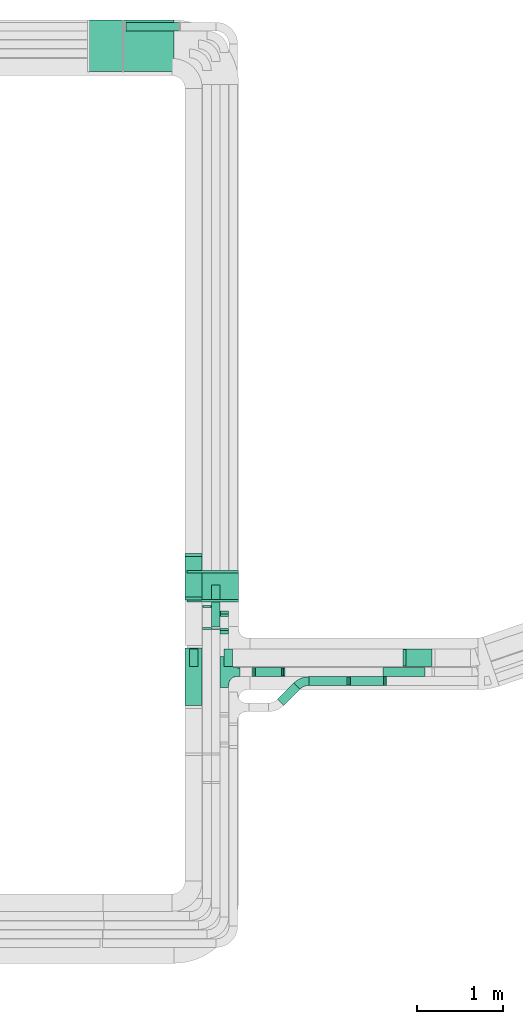
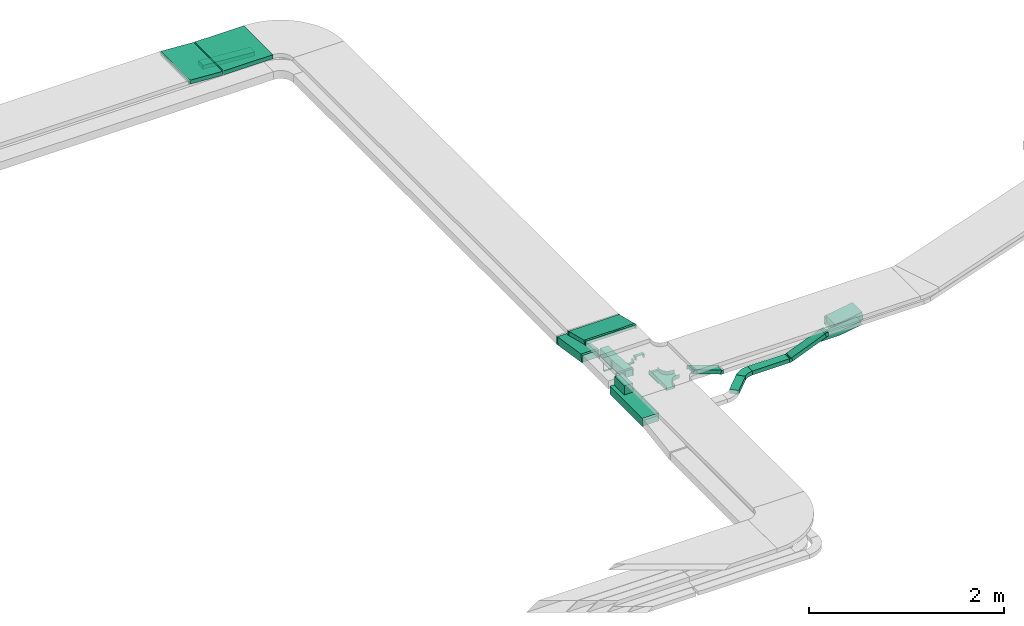
# One storey, part 23 of 28: 18 flow fittings, 13 flow segments.
"""IFC2X3 building model written with IfcOpenShell, lengths in millimetres."""

import ifcopenshell
import ifcopenshell.guid

model = None  # the IFC model being written
_history = None  # IfcOwnerHistory: only IFC2X3 demands one
_inside = {}  # id of a spatial element -> (the spatial element, [elements in it])
_under = {}  # id of a project, library or spatial element -> (it, [spatial elements below it])
_declared = {}  # id of a project -> (the project, [libraries it declares])
_typed = {}  # id of a type object -> (the type object, [elements of that type])
_made_of = {}  # id of a material, layer set ... -> (it, [elements and type objects made of it])


def new_model(schema):
    """Start an empty IFC model of exactly this schema.

    Asked for "IFC4X3", IfcOpenShell would pick the latest addendum, in which some entities
    have other attributes; the version numbers below select the first issue.
    IFC2X3 requires an IfcOwnerHistory on every rooted entity: one is made here for all.
    """
    global model, _history
    if schema == "IFC4X3":
        model = ifcopenshell.file(schema_version=(4, 3, 0, 0))
    else:
        model = ifcopenshell.file(schema=schema)
    _inside.clear()
    _under.clear()
    _declared.clear()
    _typed.clear()
    _made_of.clear()
    _history = None
    if model.schema == "IFC2X3":
        org = make("IfcOrganization", Name="unknown")
        user = make(
            "IfcPersonAndOrganization",
            ThePerson=make("IfcPerson", FamilyName="unknown"),
            TheOrganization=org,
        )
        app = make(
            "IfcApplication",
            ApplicationDeveloper=org,
            Version="unknown",
            ApplicationFullName="unknown",
            ApplicationIdentifier="unknown",
        )
        _history = make(
            "IfcOwnerHistory",
            OwningUser=user,
            OwningApplication=app,
            ChangeAction="ADDED",
            CreationDate=0,
        )
    return model


def make(cls, **values):
    """One entity of the class cls with the attributes given. An attribute that is None is left unset."""
    return model.create_entity(
        cls, **{name: value for name, value in values.items() if value is not None}
    )


def entity(cls, *values):
    """Any entity or typed value of the class cls, its attributes in the order of the schema. None: left unset."""
    e = model.create_entity(cls)
    for i, value in enumerate(values):
        if value is not None:
            e[i] = value
    return e


def rooted(cls, **values):
    """An entity with a GlobalId (a new one), such as an element, a storey or a relation."""
    return make(cls, GlobalId=ifcopenshell.guid.new(), OwnerHistory=_history, **values)


def si_unit(unit_type, name, prefix=None):
    """IfcSIUnit, for example si_unit("LENGTHUNIT", "METRE", prefix="MILLI")."""
    return make("IfcSIUnit", UnitType=unit_type, Prefix=prefix, Name=name)


def converted_unit(unit_type, name, factor, base, dimensions=None, offset=None):
    """IfcConversionBasedUnit, such as the inch: factor (a typed value) times the base unit."""
    return make(
        "IfcConversionBasedUnit"
        if offset is None
        else "IfcConversionBasedUnitWithOffset",
        ConversionOffset=offset,
        Dimensions=None
        if dimensions is None
        else entity("IfcDimensionalExponents", *dimensions),
        UnitType=unit_type,
        Name=name,
        ConversionFactor=make(
            "IfcMeasureWithUnit", ValueComponent=factor, UnitComponent=base
        ),
    )


def derived_unit(unit_type, elements):
    """IfcDerivedUnit: a product of units, each with its exponent."""
    return make(
        "IfcDerivedUnit",
        Elements=[
            make("IfcDerivedUnitElement", Unit=unit, Exponent=power)
            for unit, power in elements
        ],
        UnitType=unit_type,
    )


def assignment(units):
    """IfcUnitAssignment: the units of a project."""
    return None if units is None else make("IfcUnitAssignment", Units=units)


def point(xyz):
    """IfcCartesianPoint."""
    return None if xyz is None else make("IfcCartesianPoint", Coordinates=xyz)


def direction(xyz):
    """IfcDirection."""
    return None if xyz is None else make("IfcDirection", DirectionRatios=xyz)


def frame(location, z_axis=None, x_axis=None):
    """IfcAxis2Placement3D, a coordinate frame: its origin and axes. An axis left out is left unset."""
    return make(
        "IfcAxis2Placement3D",
        Location=point(location),
        Axis=direction(z_axis),
        RefDirection=direction(x_axis),
    )


def frame_2d(location, x_axis=None):
    """IfcAxis2Placement2D, a coordinate frame in the plane: its origin and x axis."""
    return make(
        "IfcAxis2Placement2D", Location=point(location), RefDirection=direction(x_axis)
    )


def origin():
    """The frame at (0, 0, 0) with its axes left unset."""
    return frame((0.0, 0.0, 0.0))


def origin_2d_with_axis():
    """The frame at (0, 0) in the plane with the x axis (1, 0) written out."""
    return frame_2d((0.0, 0.0), x_axis=(1.0, 0.0))


def place(relative_to, where):
    """IfcLocalPlacement: puts the frame where relative to a parent placement (None: the world)."""
    return make(
        "IfcLocalPlacement", PlacementRelTo=relative_to, RelativePlacement=where
    )


def context(
    kind, dimensions, precision=None, world=None, true_north=None, identifier=None
):
    """IfcGeometricRepresentationContext, for example the 3D "Model" context."""
    return make(
        "IfcGeometricRepresentationContext",
        ContextIdentifier=identifier,
        ContextType=kind,
        CoordinateSpaceDimension=dimensions,
        Precision=precision,
        WorldCoordinateSystem=world,
        TrueNorth=true_north,
    )


def subcontext(parent, identifier, kind, view, scale=None):
    """IfcGeometricRepresentationSubContext, for example "Body" below "Model"."""
    return make(
        "IfcGeometricRepresentationSubContext",
        ContextIdentifier=identifier,
        ContextType=kind,
        ParentContext=parent,
        TargetScale=scale,
        TargetView=view,
    )


def project(units=None, contexts=None):
    """IfcProject with its units and contexts."""
    return rooted(
        "IfcProject",
        Name="project",
        RepresentationContexts=contexts,
        UnitsInContext=assignment(units),
    )


def spatial(cls, under=None, at=None, **own):
    """A site, building, storey or space (cls), placed at a placement, below another one or the project."""
    s = rooted(cls, ObjectPlacement=at, **own)
    if under is not None:
        _under.setdefault(under.id(), (under, []))[1].append(s)
    return s


def polyline(points):
    """IfcPolyline through the points."""
    return make("IfcPolyline", Points=[point(p) for p in points])


def circle_curve(where, radius):
    """IfcCircle in the frame where."""
    return make("IfcCircle", Position=where, Radius=radius)


def parameter(value):
    """IfcParameterValue: where a trimmed curve begins or ends, as a parameter of its basis curve."""
    return model.create_entity("IfcParameterValue", value)


def trimmed(basis, trim1, trim2, sense, master):
    """IfcTrimmedCurve: the piece of a basis curve between two trims."""
    return make(
        "IfcTrimmedCurve",
        BasisCurve=basis,
        Trim1=trim1,
        Trim2=trim2,
        SenseAgreement=sense,
        MasterRepresentation=master,
    )


def segment(curve, same_sense, transition):
    """IfcCompositeCurveSegment."""
    return make(
        "IfcCompositeCurveSegment",
        Transition=transition,
        SameSense=same_sense,
        ParentCurve=curve,
    )


def composite_curve(segments, self_intersect=None):
    """IfcCompositeCurve: segments joined end to end."""
    return make("IfcCompositeCurve", Segments=segments, SelfIntersect=self_intersect)


def profile(cls, at=None, kind="AREA", **sizes):
    """A parametric profile (cls). Its sizes go by their IFC names, for example OverallWidth=200.0."""
    return make(cls, ProfileType=kind, Position=at, **sizes)


def rectangle(**sizes):
    """IfcRectangleProfileDef."""
    return profile("IfcRectangleProfileDef", **sizes)


def outline(outer, holes=None, kind="AREA"):
    """IfcArbitraryClosedProfileDef: a profile drawn as a closed curve; with holes, ...WithVoids."""
    if holes is None:
        return make("IfcArbitraryClosedProfileDef", ProfileType=kind, OuterCurve=outer)
    return make(
        "IfcArbitraryProfileDefWithVoids",
        ProfileType=kind,
        OuterCurve=outer,
        InnerCurves=holes,
    )


def extrude(swept, where, along, depth):
    """IfcExtrudedAreaSolid: the profile swept, set in the frame where, extruded along a direction by depth."""
    return make(
        "IfcExtrudedAreaSolid",
        SweptArea=swept,
        Position=where,
        ExtrudedDirection=direction(along),
        Depth=depth,
    )


def faces_of(points, faces, orient=None, outer=None):
    """IfcFace entities. A face is a list of loops; a loop is a list of indices into points, from 0.

    orient and outer hold one flag for each loop. By default every Orientation is true, the
    first loop of a face is its IfcFaceOuterBound and the others are IfcFaceBound.
    """
    made = []
    for i, loops in enumerate(faces):
        bounds = []
        for j, loop in enumerate(loops):
            is_outer = j == 0 if outer is None else outer[i][j]
            bounds.append(
                make(
                    "IfcFaceOuterBound" if is_outer else "IfcFaceBound",
                    Bound=make("IfcPolyLoop", Polygon=[points[k] for k in loop]),
                    Orientation=True if orient is None else orient[i][j],
                )
            )
        made.append(make("IfcFace", Bounds=bounds))
    return made


def faceted_brep(points, faces, orient=None, outer=None, voids=None):
    """IfcFacetedBrep: a solid bounded by flat faces; with voids (closed shells), ...WithVoids."""
    shared = [point(p) for p in points]
    hull = make("IfcClosedShell", CfsFaces=faces_of(shared, faces, orient, outer))
    if voids is None:
        return make("IfcFacetedBrep", Outer=hull)
    return make(
        "IfcFacetedBrepWithVoids",
        Outer=hull,
        Voids=[
            make(cls, CfsFaces=faces_of(shared, fs, o, b)) for cls, fs, o, b in voids
        ],
    )


def shape(context_of_items, identifier, shape_type, items):
    """IfcShapeRepresentation: the items that make up one representation, for example the "Body"."""
    return make(
        "IfcShapeRepresentation",
        ContextOfItems=context_of_items,
        RepresentationIdentifier=identifier,
        RepresentationType=shape_type,
        Items=items,
    )


def source(mapping_origin, context_of_items, identifier, shape_type, items):
    """IfcRepresentationMap: a shape defined once, which mapped items show again and again."""
    return make(
        "IfcRepresentationMap",
        MappingOrigin=mapping_origin,
        MappedRepresentation=shape(context_of_items, identifier, shape_type, items),
    )


def transform(
    local_origin,
    x_axis=None,
    y_axis=None,
    z_axis=None,
    scale=None,
    scale2=None,
    scale3=None,
    uniform=True,
):
    """IfcCartesianTransformationOperator3D, or its non-uniform kind. x_axis, y_axis, z_axis: its Axis1, 2, 3."""
    if uniform:
        return make(
            "IfcCartesianTransformationOperator3D",
            Axis1=direction(x_axis),
            Axis2=direction(y_axis),
            LocalOrigin=point(local_origin),
            Scale=scale,
            Axis3=direction(z_axis),
        )
    return make(
        "IfcCartesianTransformationOperator3DnonUniform",
        Axis1=direction(x_axis),
        Axis2=direction(y_axis),
        LocalOrigin=point(local_origin),
        Scale=scale,
        Axis3=direction(z_axis),
        Scale2=scale2,
        Scale3=scale3,
    )


def mapped(mapping_source, mapping_target):
    """IfcMappedItem: shows the shape of a source again, moved by a transform."""
    return make(
        "IfcMappedItem", MappingSource=mapping_source, MappingTarget=mapping_target
    )


def material(Name=None, Category=None):
    """IfcMaterial."""
    return make("IfcMaterial", Name=Name, Category=Category)


def made_of(thing, what):
    """Note that an element or type object is made of a material, layer set ...; save() writes the relation."""
    if what is not None:
        _made_of.setdefault(what.id(), (what, []))[1].append(thing)
    return thing


def type_object(cls, material=None, **own):
    """A type object (cls), such as IfcWallType, which elements share."""
    return made_of(rooted(cls, **own), material)


def type_shapes(of_type, sources):
    """Give a type object the sources (RepresentationMaps) that its elements show as mapped items."""
    of_type.RepresentationMaps = sources


def element(
    cls,
    number,
    at=None,
    inside=None,
    cuts=None,
    type_object=None,
    material=None,
    context=None,
    identifier="Body",
    shape_type=None,
    held_by="IfcProductDefinitionShape",
    body=None,
    shapes=None,
    **own,
):
    """One element of the class cls, such as IfcWall. Its Tag is "e" and its number.

    at: its placement. inside: the storey or other place that contains it. cuts: it is an
    opening in that element (IfcRelVoidsElement). A single representation is given by context,
    identifier, shape_type and body (its items); several are given by shapes. held_by: the class
    of the entity that holds the representations. save() writes the other relations.
    """
    e = rooted(cls, Tag="e%d" % number, ObjectPlacement=at, **own)
    if body is not None:
        shapes = [shape(context, identifier, shape_type, body)]
    if shapes is not None:
        e.Representation = make(held_by, Representations=shapes)
    if inside is not None:
        _inside.setdefault(inside.id(), (inside, []))[1].append(e)
    if cuts is not None:
        rooted(
            "IfcRelVoidsElement", RelatingBuildingElement=cuts, RelatedOpeningElement=e
        )
    if type_object is not None:
        _typed.setdefault(type_object.id(), (type_object, []))[1].append(e)
    return made_of(e, material)


def aggregate(whole, parts):
    """IfcRelAggregates: a whole, such as a stair, and the parts it consists of."""
    return rooted("IfcRelAggregates", RelatingObject=whole, RelatedObjects=parts)


def save(model, path):
    """Write the relations noted so far, then the file.

    IfcRelAggregates (storeys below a building ...), IfcRelContainedInSpatialStructure (elements
    in a storey), IfcRelDefinesByType, IfcRelAssociatesMaterial and IfcRelDeclares: one each for
    every whole, place, type object, material and project.
    """
    for whole, parts in _under.values():
        aggregate(whole, parts)
    for where, things in _inside.values():
        rooted(
            "IfcRelContainedInSpatialStructure",
            RelatedElements=things,
            RelatingStructure=where,
        )
    for kind, things in _typed.values():
        rooted("IfcRelDefinesByType", RelatedObjects=things, RelatingType=kind)
    for what, things in _made_of.values():
        rooted("IfcRelAssociatesMaterial", RelatedObjects=things, RelatingMaterial=what)
    for by, libraries in _declared.values():
        rooted("IfcRelDeclares", RelatingContext=by, RelatedDefinitions=libraries)
    model.write(path)


model = new_model("IFC2X3")

# Units and contexts
model_context = context("Model", 3, precision=0.01, world=origin(), true_north=direction((6.12303176911189e-17, 1.0)))
body_context = subcontext(model_context, "Body", "Model", "MODEL_VIEW")
ifc_project = project(units=[si_unit("LENGTHUNIT", "METRE", prefix="MILLI"), si_unit("AREAUNIT", "SQUARE_METRE"), si_unit("VOLUMEUNIT", "CUBIC_METRE"), converted_unit("PLANEANGLEUNIT", "DEGREE", entity("IfcRatioMeasure", 0.0174532925199433), si_unit("PLANEANGLEUNIT", "RADIAN"), dimensions=[0, 0, 0, 0, 0, 0, 0]), si_unit("MASSUNIT", "GRAM", prefix="KILO"), derived_unit("MASSDENSITYUNIT", [(si_unit("MASSUNIT", "GRAM", prefix="KILO"), 1), (si_unit("LENGTHUNIT", "METRE"), -3)]), derived_unit("MOMENTOFINERTIAUNIT", [(si_unit("LENGTHUNIT", "METRE"), 4)]), si_unit("TIMEUNIT", "SECOND"), si_unit("FREQUENCYUNIT", "HERTZ"), si_unit("THERMODYNAMICTEMPERATUREUNIT", "DEGREE_CELSIUS"), derived_unit("THERMALTRANSMITTANCEUNIT", [(si_unit("MASSUNIT", "GRAM", prefix="KILO"), 1), (si_unit("THERMODYNAMICTEMPERATUREUNIT", "KELVIN"), -1), (si_unit("TIMEUNIT", "SECOND"), -3)]), derived_unit("VOLUMETRICFLOWRATEUNIT", [(si_unit("LENGTHUNIT", "METRE"), 3), (si_unit("TIMEUNIT", "SECOND"), -1)]), derived_unit("MASSFLOWRATEUNIT", [(si_unit("MASSUNIT", "GRAM", prefix="KILO"), 1), (si_unit("TIMEUNIT", "SECOND"), -1)]), derived_unit("ROTATIONALFREQUENCYUNIT", [(si_unit("TIMEUNIT", "SECOND"), -1)]), si_unit("ELECTRICCURRENTUNIT", "AMPERE"), si_unit("ELECTRICVOLTAGEUNIT", "VOLT"), si_unit("POWERUNIT", "WATT"), si_unit("FORCEUNIT", "NEWTON", prefix="KILO"), si_unit("ILLUMINANCEUNIT", "LUX"), si_unit("LUMINOUSFLUXUNIT", "LUMEN"), si_unit("LUMINOUSINTENSITYUNIT", "CANDELA"), derived_unit("USERDEFINED", [(si_unit("MASSUNIT", "GRAM", prefix="KILO"), -1), (si_unit("LENGTHUNIT", "METRE"), -2), (si_unit("TIMEUNIT", "SECOND"), 3), (si_unit("LUMINOUSFLUXUNIT", "LUMEN"), 1)]), derived_unit("LINEARVELOCITYUNIT", [(si_unit("LENGTHUNIT", "METRE"), 1), (si_unit("TIMEUNIT", "SECOND"), -1)]), si_unit("PRESSUREUNIT", "PASCAL"), derived_unit("USERDEFINED", [(si_unit("LENGTHUNIT", "METRE"), -2), (si_unit("MASSUNIT", "GRAM", prefix="KILO"), 1), (si_unit("TIMEUNIT", "SECOND"), -2)]), derived_unit("LINEARFORCEUNIT", [(si_unit("MASSUNIT", "GRAM", prefix="KILO"), 1), (si_unit("LENGTHUNIT", "METRE"), 1), (si_unit("TIMEUNIT", "SECOND"), -2), (si_unit("LENGTHUNIT", "METRE"), -1)]), derived_unit("PLANARFORCEUNIT", [(si_unit("MASSUNIT", "GRAM", prefix="KILO"), 1), (si_unit("LENGTHUNIT", "METRE"), 1), (si_unit("TIMEUNIT", "SECOND"), -2), (si_unit("LENGTHUNIT", "METRE"), -2)])], contexts=[model_context])

# Site, building, storey
site_placement = place(None, origin())
site = spatial("IfcSite", under=ifc_project, at=site_placement, CompositionType="ELEMENT")
building_placement = place(site_placement, origin())
building = spatial("IfcBuilding", under=site, at=building_placement, CompositionType="ELEMENT")
storey_placement = place(building_placement, frame((0.0, 0.0, 4200.0)))
storey = spatial("IfcBuildingStorey", under=building, at=storey_placement, CompositionType="ELEMENT", Elevation=4200.0)

# Flow segments
cable_carrier_segment_type = type_object("IfcCableCarrierSegmentType", PredefinedType="CABLETRAYSEGMENT")
flow_segment_1_placement = place(storey_placement, frame((60757.94, 15566.15, 2773.4)))
element("IfcFlowSegment", 1, at=flow_segment_1_placement, inside=storey, type_object=cable_carrier_segment_type, context=body_context, shape_type="SweptSolid", body=[
    extrude(rectangle(XDim=585.094690368982, YDim=600.000000000002, at=origin_2d_with_axis()), frame((292.55, 300.0, 0.0), z_axis=(0.0, 0.0, 1.0), x_axis=(-1.0, 0.0, 0.0)), (0.0, 0.0, 1.0), 49.9999999999995),
])
flow_segment_2_placement = place(storey_placement, frame((60355.69, 15566.15, 2773.87)))
element("IfcFlowSegment", 2, at=flow_segment_2_placement, inside=storey, type_object=cable_carrier_segment_type, context=body_context, shape_type="SweptSolid", body=[
    extrude(rectangle(XDim=49.9999999999996, YDim=388.064289471167, at=frame_2d((0.0, 0.0), x_axis=(0.0, 1.0))), frame((195.2, 0.0, 36.92), z_axis=(0.0, 1.0, 0.0), x_axis=(-0.998094861417354, 0.0, 0.0616980357245901)), (0.0, 0.0, 1.0), 600.000000000002),
])
flow_segment_3_placement = place(storey_placement, frame((60781.94, 16039.18, 2500.58)))
element("IfcFlowSegment", 3, at=flow_segment_3_placement, inside=storey, type_object=cable_carrier_segment_type, context=body_context, shape_type="SweptSolid", body=[
    extrude(rectangle(XDim=50.0000000000008, YDim=99.9999999999989, at=frame_2d((0.0, 0.0), x_axis=(0.0, 1.0))), frame((1.84, 50.0, 70.61), z_axis=(0.997292368727615, 0.0, -0.0735386379916224), x_axis=(0.0, 1.0, 0.0)), (0.0, 0.0, 1.0), 621.075687126531),
])
flow_segment_4_placement = place(storey_placement, frame((64021.59, 8663.79, 2585.29)))
element("IfcFlowSegment", 4, at=flow_segment_4_placement, inside=storey, type_object=cable_carrier_segment_type, context=body_context, shape_type="SweptSolid", body=[
    extrude(rectangle(XDim=99.9999999999992, YDim=200.0, at=origin_2d_with_axis()), frame((7.82, 100.0, 49.38), z_axis=(0.987688340595139, 0.0, 0.156434465040222), x_axis=(-0.156434465040222, 0.0, 0.987688340595139)), (0.0, 0.0, 1.0), 322.266039926172),
])
flow_segment_5_placement = place(storey_placement, frame((61494.03, 9426.2, 2776.99)))
element("IfcFlowSegment", 5, at=flow_segment_5_placement, inside=storey, type_object=cable_carrier_segment_type, context=body_context, shape_type="SweptSolid", body=[
    extrude(rectangle(XDim=49.9999999999996, YDim=332.374456454339, at=frame_2d((0.0, 0.0), x_axis=(0.0, 1.0))), frame((0.0, 167.3, 64.46), z_axis=(1.0, 0.0, 0.0), x_axis=(0.0, -0.970295726275995, 0.241921895599672)), (0.0, 0.0, 1.0), 600.000000000002),
])
flow_segment_6_placement = place(storey_placement, frame((62270.54, 8547.45, 2636.4)))
element("IfcFlowSegment", 6, at=flow_segment_6_placement, inside=storey, type_object=cable_carrier_segment_type, context=body_context, shape_type="SweptSolid", body=[
    extrude(rectangle(XDim=49.9999999999965, YDim=100.000000000001, at=origin_2d_with_axis()), frame((8.55, 50.0, 141.2), z_axis=(0.939692620785895, 0.0, -0.342020143325705), x_axis=(0.342020143325705, 0.0, 0.939692620785895)), (0.0, 0.0, 1.0), 344.163283664483),
])
flow_segment_7_placement = place(storey_placement, frame((61471.18, 9451.56, 2548.89)))
element("IfcFlowSegment", 7, at=flow_segment_7_placement, inside=storey, type_object=cable_carrier_segment_type, context=body_context, shape_type="SweptSolid", body=[
    extrude(rectangle(XDim=99.9999999999984, YDim=494.262005377991, at=frame_2d((0.0, 0.0), x_axis=(0.0, 1.0))), frame((0.0, 251.91, 88.04), z_axis=(1.0, 0.0, 0.0), x_axis=(0.0, -0.987688340595126, 0.156434465040307)), (0.0, 0.0, 1.0), 200.000000000007),
])
flow_segment_8_placement = place(storey_placement, frame((62546.48, 8211.11, 2577.31)))
element("IfcFlowSegment", 8, at=flow_segment_8_placement, inside=storey, type_object=cable_carrier_segment_type, context=body_context, shape_type="SweptSolid", body=[
    extrude(rectangle(XDim=265.58357237913, YDim=100.000000000002, at=origin_2d_with_axis()), frame((129.25, 129.25, 0.0), z_axis=(0.0, 0.0, 1.0), x_axis=(0.707106781186535, 0.70710678118656, 0.0)), (0.0, 0.0, 1.0), 49.9999999999995),
])
flow_segment_9_placement = place(storey_placement, frame((63374.05, 8443.55, 2585.01)))
element("IfcFlowSegment", 9, at=flow_segment_9_placement, inside=storey, type_object=cable_carrier_segment_type, context=body_context, shape_type="SweptSolid", body=[
    extrude(rectangle(XDim=49.9999999999932, YDim=99.9999999999989, at=origin_2d_with_axis()), frame((9.37, 50.0, 23.18), z_axis=(0.927183847648221, 0.0, 0.374606610539964), x_axis=(-0.374606610539964, 0.0, 0.927183847648221)), (0.0, 0.0, 1.0), 429.833078956127),
])
flow_segment_10_placement = place(storey_placement, frame((62912.76, 8443.55, 2577.31)))
element("IfcFlowSegment", 10, at=flow_segment_10_placement, inside=storey, type_object=cable_carrier_segment_type, context=body_context, shape_type="SweptSolid", body=[
    extrude(rectangle(XDim=440.41961669144, YDim=99.9999999999989, at=origin_2d_with_axis()), frame((220.21, 50.0, 0.0)), (0.0, 0.0, 1.0), 49.9999999999995),
])
flow_segment_11_placement = place(storey_placement, frame((61471.18, 8206.58, 2582.6)))
element("IfcFlowSegment", 11, at=flow_segment_11_placement, inside=storey, type_object=cable_carrier_segment_type, context=body_context, shape_type="SweptSolid", body=[
    extrude(rectangle(XDim=667.207311601806, YDim=200.000000000007, at=origin_2d_with_axis()), frame((100.0, 333.6, 0.0), z_axis=(0.0, 0.0, 1.0), x_axis=(0.0, 1.0, 0.0)), (0.0, 0.0, 1.0), 99.9999999999989),
])
flow_segment_12_placement = place(storey_placement, frame((61921.36, 8663.79, 2682.6)))
element("IfcFlowSegment", 12, at=flow_segment_12_placement, inside=storey, type_object=cable_carrier_segment_type, context=body_context, shape_type="SweptSolid", body=[
    extrude(rectangle(XDim=200.0, YDim=99.9999999999946, at=origin_2d_with_axis()), frame((50.0, 100.0, 0.0), z_axis=(0.0, 0.0, 1.0), x_axis=(0.0, -1.0, 0.0)), (0.0, 0.0, 1.0), 29.9999999999921),
])
flow_segment_13_placement = place(storey_placement, frame((61521.18, 8663.79, 2682.6)))
element("IfcFlowSegment", 13, at=flow_segment_13_placement, inside=storey, type_object=cable_carrier_segment_type, context=body_context, shape_type="SweptSolid", body=[
    extrude(rectangle(XDim=200.0, YDim=99.9999999999946, at=origin_2d_with_axis()), frame((50.0, 100.0, 0.0), z_axis=(0.0, 0.0, 1.0), x_axis=(0.0, 1.0, 0.0)), (0.0, 0.0, 1.0), 111.353041875385),
])

# Flow fittings
ifc_material = material()
cable_carrier_fitting_type_1 = type_object("IfcCableCarrierFittingType", PredefinedType="NOTDEFINED", material=ifc_material)
shared_shape_1 = source(origin(), body_context, "Body", "Brep", [
    faceted_brep([(-53.41, -124.12, 25.0), (-50.0, -150.0, 25.0), (-50.0, -180.0, 25.0), (-49.2, -180.0, 25.0), (-49.2, -150.0, 25.0), (-52.63, -123.91, 25.0), (-62.7, -99.6, 25.0), (-78.72, -78.72, 25.0), (-99.6, -62.7, 25.0), (-123.91, -52.63, 25.0), (-150.0, -49.2, 25.0), (-180.0, -49.2, 25.0), (-180.0, -50.0, 25.0), (-150.0, -50.0, 25.0), (-124.12, -53.41, 25.0), (-100.0, -63.4, 25.0), (-79.29, -79.29, 25.0), (-63.4, -100.0, 25.0), (180.0, -50.0, 25.0), (180.0, -49.2, 25.0), (150.0, -49.2, 25.0), (123.91, -52.63, 25.0), (99.6, -62.7, 25.0), (78.72, -78.72, 25.0), (62.7, -99.6, 25.0), (52.63, -123.91, 25.0), (49.2, -150.0, 25.0), (49.2, -180.0, 25.0), (50.0, -180.0, 25.0), (50.0, -150.0, 25.0), (53.41, -124.12, 25.0), (63.4, -100.0, 25.0), (79.29, -79.29, 25.0), (100.0, -63.4, 25.0), (124.12, -53.41, 25.0), (150.0, -50.0, 25.0), (180.0, 49.2, 25.0), (180.0, 50.0, 25.0), (-180.0, 50.0, 25.0), (-180.0, 49.2, 25.0), (-180.0, -50.0, -25.0), (-180.0, 50.0, -25.0), (180.0, 50.0, -25.0), (180.0, -50.0, -25.0), (150.0, -50.0, -25.0), (124.12, -53.41, -25.0), (100.0, -63.4, -25.0), (79.29, -79.29, -25.0), (63.4, -100.0, -25.0), (53.41, -124.12, -25.0), (50.0, -150.0, -25.0), (50.0, -180.0, -25.0), (-50.0, -180.0, -25.0), (-50.0, -150.0, -25.0), (-53.41, -124.12, -25.0), (-63.4, -100.0, -25.0), (-79.29, -79.29, -25.0), (-100.0, -63.4, -25.0), (-124.12, -53.41, -25.0), (-150.0, -50.0, -25.0), (-50.0, -150.0, -24.2), (49.2, -180.0, -24.2), (-49.2, -180.0, -24.2), (-49.2, -150.0, -24.2), (-150.0, -49.2, -24.2), (-180.0, -49.2, -24.2), (180.0, -49.2, -24.2), (150.0, -49.2, -24.2), (-180.0, 49.2, -24.2), (-150.0, -50.0, -24.2), (150.0, -50.0, -24.2), (180.0, 49.2, -24.2), (49.2, -150.0, -24.2), (50.0, -150.0, -24.2), (-123.91, -52.63, -24.2), (-99.6, -62.7, -24.2), (-78.72, -78.72, -24.2), (-62.7, -99.6, -24.2), (-52.63, -123.91, -24.2), (52.63, -123.91, -24.2), (62.7, -99.6, -24.2), (78.72, -78.72, -24.2), (99.6, -62.7, -24.2), (123.91, -52.63, -24.2)], [[[0, 1, 2, 3, 4, 5, 6, 7, 8, 9, 10, 11, 12, 13, 14, 15, 16, 17]], [[18, 19, 20, 21, 22, 23, 24, 25, 26, 27, 28, 29, 30, 31, 32, 33, 34, 35]], [[36, 37, 38, 39]], [[40, 41, 42, 43, 44, 45, 46, 47, 48, 49, 50, 51, 52, 53, 54, 55, 56, 57, 58, 59]], [[2, 1, 60, 53, 52]], [[3, 2, 52, 51, 28, 27, 61, 62]], [[4, 3, 62, 63]], [[11, 10, 64, 65]], [[20, 19, 66, 67]], [[39, 38, 41, 40, 12, 11, 65, 68]], [[13, 12, 40, 59, 69]], [[18, 35, 70, 44, 43]], [[19, 18, 43, 42, 37, 36, 71, 66]], [[27, 26, 72, 61]], [[29, 28, 51, 50, 73]], [[38, 37, 42, 41]], [[36, 39, 68, 71]], [[68, 65, 64, 74, 75, 76, 77, 78, 63, 62, 61, 72, 79, 80, 81, 82, 83, 67, 66, 71]], [[14, 13, 69, 59, 58]], [[58, 57, 15, 14]], [[15, 57, 56, 16]], [[0, 17, 55, 54]], [[0, 54, 53, 60, 1]], [[55, 17, 16, 56]], [[5, 4, 63, 78]], [[6, 5, 78, 77]], [[7, 6, 77, 76]], [[8, 7, 76, 75]], [[9, 8, 75, 74]], [[10, 9, 74, 64]], [[21, 20, 67, 83]], [[22, 21, 83, 82]], [[23, 22, 82, 81]], [[81, 80, 24, 23]], [[24, 80, 79, 25]], [[79, 72, 26, 25]], [[30, 29, 73, 50, 49]], [[31, 30, 49, 48]], [[31, 48, 47, 32]], [[33, 32, 47, 46]], [[45, 34, 33, 46]], [[34, 45, 44, 70, 35]]]),
])
type_shapes(cable_carrier_fitting_type_1, [shared_shape_1])
flow_fitting_1_placement = place(storey_placement, frame((61928.34, 8597.45, 2782.63), z_axis=(0.0, 0.0, 1.0), x_axis=(0.0, 1.0, 0.0)))
element("IfcFlowFitting", 14, at=flow_fitting_1_placement, inside=storey, type_object=cable_carrier_fitting_type_1, material=ifc_material, Name="470_DKC_S5_T", context=body_context, shape_type="MappedRepresentation", body=[
    mapped(shared_shape_1, transform((0.0, 0.0, 0.0), scale=1.0)),
])
cable_carrier_fitting_type_2 = type_object("IfcCableCarrierFittingType", PredefinedType="NOTDEFINED", material=ifc_material)
shared_shape_2 = source(origin(), body_context, "Body", "Brep", [
    faceted_brep([(-13.26, -50.0, 100.0), (-13.26, 50.0, 100.0), (-13.26, 50.0, 97.46), (-13.26, -47.46, 97.46), (-13.26, -47.46, -97.46), (-13.26, 50.0, -97.46), (-13.26, 50.0, -100.0), (-13.26, -50.0, -100.0), (20.92, -47.31, 100.0), (20.92, -47.31, -100.0), (5.28, 51.46, -100.0), (5.28, 51.46, -97.46), (20.52, -44.8, -97.46), (20.52, -44.8, 97.46), (5.28, 51.46, 97.46), (5.28, 51.46, 100.0), (3.94, -50.0, 100.0), (-3.94, 50.0, 100.0), (-3.94, 50.0, 97.46), (3.74, -47.46, 97.46), (3.74, -47.46, -97.46), (-3.94, 50.0, -97.46), (-3.94, 50.0, -100.0), (3.94, -50.0, -100.0)], [[[0, 1, 2, 3, 4, 5, 6, 7]], [[8, 9, 10, 11, 12, 13, 14, 15]], [[1, 0, 16, 8, 15, 17]], [[2, 1, 17, 18]], [[3, 2, 18, 14, 13, 19]], [[4, 3, 19, 20]], [[5, 4, 20, 12, 11, 21]], [[6, 5, 21, 22]], [[7, 6, 22, 10, 9, 23]], [[0, 7, 23, 16]], [[18, 17, 15, 14]], [[20, 19, 13, 12]], [[22, 21, 11, 10]], [[16, 23, 9, 8]]]),
])
type_shapes(cable_carrier_fitting_type_2, [shared_shape_2])
for number, where, z_axis, x_axis in (
    (15, (61571.18, 9960.66, 2596.2), (-1.0, 0.0, 0.0), (0.0, -1.0, 0.0)),
    (16, (64016.31, 8763.79, 2632.6), (0.0, 1.0, 0.0), (-0.987688340595138, 0.0, -0.156434465040229)),
    (17, (61571.18, 9446.28, 2677.67), (1.0, 0.0, 0.0), (0.0, -0.987688340595126, 0.156434465040307)),
):
    element("IfcFlowFitting", number, at=place(storey_placement, frame(where, z_axis=z_axis, x_axis=x_axis)), inside=storey, type_object=cable_carrier_fitting_type_2, material=ifc_material, context=body_context, shape_type="MappedRepresentation", body=[
        mapped(shared_shape_2, transform((0.0, 0.0, 0.0), scale=1.0)),
    ])
cable_carrier_fitting_type_3 = type_object("IfcCableCarrierFittingType", PredefinedType="NOTDEFINED", material=ifc_material)
shared_shape_3 = source(origin(), body_context, "Body", "Brep", [
    faceted_brep([(-11.75, -25.0, 300.0), (-11.75, 25.0, 300.0), (-11.75, 25.0, 297.46), (-11.75, -22.46, 297.46), (-11.75, -22.46, -297.46), (-11.75, 25.0, -297.46), (-11.75, 25.0, -300.0), (-11.75, -25.0, -300.0), (17.45, -21.41, 300.0), (17.45, -21.41, -300.0), (5.36, 27.1, -300.0), (5.36, 27.1, -297.46), (16.84, -18.95, -297.46), (16.84, -18.95, 297.46), (5.36, 27.1, 297.46), (5.36, 27.1, 300.0), (3.07, -25.0, 300.0), (-3.07, 25.0, 300.0), (-3.07, 25.0, 297.46), (2.76, -22.46, 297.46), (2.76, -22.46, -297.46), (-3.07, 25.0, -297.46), (-3.07, 25.0, -300.0), (3.07, -25.0, -300.0)], [[[0, 1, 2, 3, 4, 5, 6, 7]], [[8, 9, 10, 11, 12, 13, 14, 15]], [[1, 0, 16, 8, 15, 17]], [[2, 1, 17, 18]], [[3, 2, 18, 14, 13, 19]], [[4, 3, 19, 20]], [[5, 4, 20, 12, 11, 21]], [[6, 5, 21, 22]], [[7, 6, 22, 10, 9, 23]], [[0, 7, 23, 16]], [[18, 17, 15, 14]], [[20, 19, 13, 12]], [[22, 21, 11, 10]], [[16, 23, 9, 8]]]),
])
type_shapes(cable_carrier_fitting_type_3, [shared_shape_3])
for number, where, z_axis, x_axis in (
    (18, (61794.03, 9766.15, 2798.4), (-1.0, 0.0, 0.0), (0.0, -1.0, 0.0)),
    (19, (61794.03, 9420.84, 2884.5), (-1.0, 0.0, 0.0), (0.0, 1.0, 0.0)),
):
    element("IfcFlowFitting", number, at=place(storey_placement, frame(where, z_axis=z_axis, x_axis=x_axis)), inside=storey, type_object=cable_carrier_fitting_type_3, material=ifc_material, context=body_context, shape_type="MappedRepresentation", body=[
        mapped(shared_shape_3, transform((0.0, 0.0, 0.0), scale=1.0)),
    ])
cable_carrier_fitting_type_4 = type_object("IfcCableCarrierFittingType", PredefinedType="NOTDEFINED", material=ifc_material)
shared_shape_4 = source(origin(), body_context, "Body", "Brep", [
    faceted_brep([(-27.78, -25.0, 50.0), (-27.78, 25.0, 50.0), (-27.78, 25.0, 47.46), (-27.78, -22.46, 47.46), (-27.78, -22.46, -47.46), (-27.78, 25.0, -47.46), (-27.78, 25.0, -50.0), (-27.78, -25.0, -50.0), (37.32, 1.97, 50.0), (37.32, 1.97, -50.0), (1.97, 37.32, -50.0), (1.97, 37.32, -47.46), (35.53, 3.76, -47.46), (35.53, 3.76, 47.46), (1.97, 37.32, 47.46), (1.97, 37.32, 50.0), (10.36, -25.0, 50.0), (-10.36, 25.0, 50.0), (-10.36, 25.0, 47.46), (9.3, -22.46, 47.46), (9.3, -22.46, -47.46), (-10.36, 25.0, -47.46), (-10.36, 25.0, -50.0), (10.36, -25.0, -50.0)], [[[0, 1, 2, 3, 4, 5, 6, 7]], [[8, 9, 10, 11, 12, 13, 14, 15]], [[1, 0, 16, 8, 15, 17]], [[2, 1, 17, 18]], [[3, 2, 18, 14, 13, 19]], [[4, 3, 19, 20]], [[5, 4, 20, 12, 11, 21]], [[6, 5, 21, 22]], [[7, 6, 22, 10, 9, 23]], [[0, 7, 23, 16]], [[18, 17, 15, 14]], [[20, 19, 13, 12]], [[22, 21, 11, 10]], [[16, 23, 9, 8]]]),
])
type_shapes(cable_carrier_fitting_type_4, [shared_shape_4])
for number, where, z_axis, x_axis in (
    (20, (61928.34, 9279.31, 2571.7), (-1.0, 0.0, 0.0), (0.0, -1.0, 0.0)),
    (21, (61928.34, 9068.38, 2782.63), (1.0, 0.0, 0.0), (0.0, -0.707106781186476, 0.707106781186619)),
):
    element("IfcFlowFitting", number, at=place(storey_placement, frame(where, z_axis=z_axis, x_axis=x_axis)), inside=storey, type_object=cable_carrier_fitting_type_4, material=ifc_material, context=body_context, shape_type="MappedRepresentation", body=[
        mapped(shared_shape_4, transform((0.0, 0.0, 0.0), scale=1.0)),
    ])
cable_carrier_fitting_type_5 = type_object("IfcCableCarrierFittingType", PredefinedType="NOTDEFINED", material=ifc_material)
shared_shape_5 = source(origin(), body_context, "Body", "Brep", [
    faceted_brep([(-14.7, -25.0, 50.0), (-14.7, 25.0, 50.0), (-14.7, 25.0, 47.46), (-14.7, -22.46, 47.46), (-14.7, -22.46, -47.46), (-14.7, 25.0, -47.46), (-14.7, 25.0, -50.0), (-14.7, -25.0, -50.0), (22.36, -18.47, 50.0), (22.36, -18.47, -50.0), (5.26, 28.52, -50.0), (5.26, 28.52, -47.46), (21.49, -16.08, -47.46), (21.49, -16.08, 47.46), (5.26, 28.52, 47.46), (5.26, 28.52, 50.0), (4.41, -25.0, 50.0), (-4.41, 25.0, 50.0), (-4.41, 25.0, 47.46), (3.96, -22.46, 47.46), (3.96, -22.46, -47.46), (-4.41, 25.0, -47.46), (-4.41, 25.0, -50.0), (4.41, -25.0, -50.0)], [[[0, 1, 2, 3, 4, 5, 6, 7]], [[8, 9, 10, 11, 12, 13, 14, 15]], [[1, 0, 16, 8, 15, 17]], [[2, 1, 17, 18]], [[3, 2, 18, 14, 13, 19]], [[4, 3, 19, 20]], [[5, 4, 20, 12, 11, 21]], [[6, 5, 21, 22]], [[7, 6, 22, 10, 9, 23]], [[0, 7, 23, 16]], [[18, 17, 15, 14]], [[20, 19, 13, 12]], [[22, 21, 11, 10]], [[16, 23, 9, 8]]]),
])
type_shapes(cable_carrier_fitting_type_5, [shared_shape_5])
for number, where, z_axis, x_axis in (
    (22, (62616.31, 8597.45, 2654.87), (0.0, 1.0, 0.0), (-1.0, 0.0, 0.0)),
    (23, (62265.28, 8597.45, 2782.63), (0.0, 1.0, 0.0), (1.0, 0.0, 0.0)),
):
    element("IfcFlowFitting", number, at=place(storey_placement, frame(where, z_axis=z_axis, x_axis=x_axis)), inside=storey, type_object=cable_carrier_fitting_type_5, material=ifc_material, context=body_context, shape_type="MappedRepresentation", body=[
        mapped(shared_shape_5, transform((0.0, 0.0, 0.0), scale=1.0)),
    ])
cable_carrier_fitting_type_6 = type_object("IfcCableCarrierFittingType", PredefinedType="NOTDEFINED", material=ifc_material)
shared_shape_6 = source(origin(), body_context, "Body", "Brep", [
    faceted_brep([(-10.5, -50.0, 50.0), (-10.5, 50.0, 50.0), (-10.5, 50.0, 47.46), (-10.5, -47.46, 47.46), (-10.5, -47.46, -47.46), (-10.5, 50.0, -47.46), (-10.5, 50.0, -50.0), (-10.5, -50.0, -50.0), (15.67, -48.63, 50.0), (15.67, -48.63, -50.0), (5.22, 50.82, -50.0), (5.22, 50.82, -47.46), (15.41, -46.1, -47.46), (15.41, -46.1, 47.46), (5.22, 50.82, 47.46), (5.22, 50.82, 50.0), (2.62, -50.0, 50.0), (-2.62, 50.0, 50.0), (-2.62, 50.0, 47.46), (2.49, -47.46, 47.46), (2.49, -47.46, -47.46), (-2.62, 50.0, -47.46), (-2.62, 50.0, -50.0), (2.62, -50.0, -50.0)], [[[0, 1, 2, 3, 4, 5, 6, 7]], [[8, 9, 10, 11, 12, 13, 14, 15]], [[1, 0, 16, 8, 15, 17]], [[2, 1, 17, 18]], [[3, 2, 18, 14, 13, 19]], [[4, 3, 19, 20]], [[5, 4, 20, 12, 11, 21]], [[6, 5, 21, 22]], [[7, 6, 22, 10, 9, 23]], [[0, 7, 23, 16]], [[18, 17, 15, 14]], [[20, 19, 13, 12]], [[22, 21, 11, 10]], [[16, 23, 9, 8]]]),
])
type_shapes(cable_carrier_fitting_type_6, [shared_shape_6])
for number, where, z_axis, x_axis in (
    (24, (61828.68, 9101.44, 2580.73), (1.0, 0.0, 0.0), (0.0, -0.994521895368246, 0.104528463267915)),
    (25, (61726.28, 9101.45, 2580.73), (1.0, 0.0, 0.0), (0.0, -0.994521895368246, 0.104528463267915)),
    (26, (61726.28, 9361.31, 2553.42), (1.0, 0.0, 0.0), (0.0, 0.994521895368246, -0.10452846326791)),
):
    element("IfcFlowFitting", number, at=place(storey_placement, frame(where, z_axis=z_axis, x_axis=x_axis)), inside=storey, type_object=cable_carrier_fitting_type_6, material=ifc_material, context=body_context, shape_type="MappedRepresentation", body=[
        mapped(shared_shape_6, transform((0.0, 0.0, 0.0), scale=1.0)),
    ])
cable_carrier_fitting_type_7 = type_object("IfcCableCarrierFittingType", PredefinedType="NOTDEFINED", material=ifc_material)
shared_shape_7 = source(origin(), body_context, "Body", "Brep", [
    faceted_brep([(-15.69, -25.0, 50.0), (-15.69, 25.0, 50.0), (-15.69, 25.0, 47.46), (-15.69, -22.46, 47.46), (-15.69, -22.46, -47.46), (-15.69, 25.0, -47.46), (-15.69, 25.0, -50.0), (-15.69, -25.0, -50.0), (23.91, -17.3, 50.0), (23.91, -17.3, -50.0), (5.18, 29.06, -50.0), (5.18, 29.06, -47.46), (22.96, -14.95, -47.46), (22.96, -14.95, 47.46), (5.18, 29.06, 47.46), (5.18, 29.06, 50.0), (4.86, -25.0, 50.0), (-4.86, 25.0, 50.0), (-4.86, 25.0, 47.46), (4.37, -22.46, 47.46), (4.37, -22.46, -47.46), (-4.86, 25.0, -47.46), (-4.86, 25.0, -50.0), (4.86, -25.0, -50.0)], [[[0, 1, 2, 3, 4, 5, 6, 7]], [[8, 9, 10, 11, 12, 13, 14, 15]], [[1, 0, 16, 8, 15, 17]], [[2, 1, 17, 18]], [[3, 2, 18, 14, 13, 19]], [[4, 3, 19, 20]], [[5, 4, 20, 12, 11, 21]], [[6, 5, 21, 22]], [[7, 6, 22, 10, 9, 23]], [[0, 7, 23, 16]], [[18, 17, 15, 14]], [[20, 19, 13, 12]], [[22, 21, 11, 10]], [[16, 23, 9, 8]]]),
])
type_shapes(cable_carrier_fitting_type_7, [shared_shape_7])
for number, where, z_axis, x_axis in (
    (27, (63796.5, 8493.55, 2775.08), (0.0, -1.0, 0.0), (-1.0, 0.0, 0.0)),
    (28, (63368.87, 8493.55, 2602.31), (0.0, 1.0, 0.0), (-0.927183847648195, 0.0, -0.37460661054003)),
):
    element("IfcFlowFitting", number, at=place(storey_placement, frame(where, z_axis=z_axis, x_axis=x_axis)), inside=storey, type_object=cable_carrier_fitting_type_7, material=ifc_material, context=body_context, shape_type="MappedRepresentation", body=[
        mapped(shared_shape_7, transform((0.0, 0.0, 0.0), scale=1.0)),
    ])
cable_carrier_fitting_type_8 = type_object("IfcCableCarrierFittingType", Name="470_DKC_S5_CS 90 internal vertical angle:-", PredefinedType="NOTDEFINED", material=ifc_material)
shared_shape_8 = source(origin(), body_context, "Body", "SweptSolid", [
    extrude(outline(composite_curve([segment(polyline([(-248.78, -35.19), (-10.22, -35.19)]), True, "CONTINUOUS"), segment(trimmed(circle_curve(frame_2d((-10.22, 129.81), x_axis=(0.0, -1.0)), 164.999999999999), [parameter(0.0)], [parameter(8.99999999999889)], True, "PARAMETER"), True, "CONTINUOUS"), segment(polyline([(15.6, -33.16), (251.22, 4.16)]), True, "CONTINUOUS"), segment(polyline([(251.22, 4.16), (243.4, 53.54)]), True, "CONTINUOUS"), segment(polyline([(243.4, 53.54), (7.77, 16.22)]), True, "CONTINUOUS"), segment(trimmed(circle_curve(frame_2d((-10.22, 129.81), x_axis=(0.0, -1.0)), 114.999999999999), [parameter(0.0)], [parameter(8.99999999999889)], True, "PARAMETER"), False, "CONTINUOUS"), segment(polyline([(-10.22, 14.81), (-248.78, 14.81)]), True, "CONTINUOUS"), segment(polyline([(-248.78, 14.81), (-248.78, -35.19)]), True, "CONTINUOUS")], self_intersect=False)), frame((-0.8, 10.19, -50.0)), (0.0, 0.0, 1.0), 99.9999999999999),
])
type_shapes(cable_carrier_fitting_type_8, [shared_shape_8])
flow_fitting_2_placement = place(storey_placement, frame((64016.31, 8597.45, 2654.87), z_axis=(0.0, 1.0, 0.0), x_axis=(-0.987688340595139, 0.0, -0.156434465040224)))
element("IfcFlowFitting", 29, at=flow_fitting_2_placement, inside=storey, type_object=cable_carrier_fitting_type_8, material=ifc_material, Name="470_DKC_S5_CS 90 internal vertical angle:-", ObjectType="470_DKC_S5_CS 90 internal vertical angle:-", context=body_context, shape_type="MappedRepresentation", body=[
    mapped(shared_shape_8, transform((0.0, 0.0, 0.0), scale=1.0)),
])
cable_carrier_fitting_type_9 = type_object("IfcCableCarrierFittingType", Name="470_DKC_S5_Variable Angle Elbow 0-45:-", PredefinedType="NOTDEFINED", material=ifc_material)
shared_shape_9 = source(origin(), body_context, "Body", "SweptSolid", [
    extrude(outline(composite_curve([segment(polyline([(-71.64, -79.47), (-70.64, -79.47)]), True, "CONTINUOUS"), segment(trimmed(circle_curve(frame_2d((-70.64, 170.53), x_axis=(0.0, -1.0)), 250.0), [parameter(0.0)], [parameter(45.0)], True, "PARAMETER"), True, "CONTINUOUS"), segment(polyline([(106.14, -6.24), (106.85, -5.54)]), True, "CONTINUOUS"), segment(polyline([(106.85, -5.54), (36.14, 65.17)]), True, "CONTINUOUS"), segment(polyline([(36.14, 65.17), (35.43, 64.47)]), True, "CONTINUOUS"), segment(trimmed(circle_curve(frame_2d((-70.64, 170.53), x_axis=(0.0, -1.0)), 150.0), [parameter(0.0)], [parameter(45.0)], True, "PARAMETER"), False, "CONTINUOUS"), segment(polyline([(-70.64, 20.53), (-71.64, 20.53)]), True, "CONTINUOUS"), segment(polyline([(-71.64, 20.53), (-71.64, -79.47)]), True, "CONTINUOUS")], self_intersect=False)), frame((-12.21, 29.47, -25.0)), (0.0, 0.0, 1.0), 49.9999999999999),
])
type_shapes(cable_carrier_fitting_type_9, [shared_shape_9])
flow_fitting_3_placement = place(storey_placement, frame((62828.91, 8493.55, 2602.31), z_axis=(0.0, 0.0, 1.0), x_axis=(-1.0, 0.0, 0.0)))
element("IfcFlowFitting", 30, at=flow_fitting_3_placement, inside=storey, type_object=cable_carrier_fitting_type_9, material=ifc_material, Name="470_DKC_S5_Variable Angle Elbow 0-45:-", ObjectType="470_DKC_S5_Variable Angle Elbow 0-45:-", context=body_context, shape_type="MappedRepresentation", body=[
    mapped(shared_shape_9, transform((0.0, 0.0, 0.0), scale=1.0)),
])
cable_carrier_fitting_type_10 = type_object("IfcCableCarrierFittingType", Name="470_DKC_S5_CS 90 internal vertical angle:-", PredefinedType="NOTDEFINED", material=ifc_material)
shared_shape_10 = source(origin(), body_context, "Body", "SweptSolid", [
    extrude(outline(composite_curve([segment(polyline([(-247.71, -56.71), (-8.3, -56.71)]), True, "CONTINUOUS"), segment(trimmed(circle_curve(frame_2d((-8.3, 158.29), x_axis=(0.0, -1.0)), 214.999999999999), [parameter(0.0)], [parameter(6.00454625180131)], True, "PARAMETER"), True, "CONTINUOUS"), segment(polyline([(14.19, -55.53), (252.29, -30.49)]), True, "CONTINUOUS"), segment(polyline([(252.29, -30.49), (241.83, 68.96)]), True, "CONTINUOUS"), segment(polyline([(241.83, 68.96), (3.73, 43.92)]), True, "CONTINUOUS"), segment(trimmed(circle_curve(frame_2d((-8.3, 158.29), x_axis=(0.0, -1.0)), 114.999999999999), [parameter(0.0)], [parameter(6.00454625180131)], True, "PARAMETER"), False, "CONTINUOUS"), segment(polyline([(-8.3, 43.29), (-247.71, 43.29)]), True, "CONTINUOUS"), segment(polyline([(-247.71, 43.29), (-247.71, -56.71)]), True, "CONTINUOUS")], self_intersect=False)), frame((-0.35, 6.71, -50.0)), (0.0, 0.0, 1.0), 99.9999999999999),
])
type_shapes(cable_carrier_fitting_type_10, [shared_shape_10])
flow_fitting_4_placement = place(storey_placement, frame((61828.68, 9361.31, 2553.42), z_axis=(1.0, 0.0, 0.0), x_axis=(0.0, 0.994521895368246, -0.104528463267915)))
element("IfcFlowFitting", 31, at=flow_fitting_4_placement, inside=storey, type_object=cable_carrier_fitting_type_10, material=ifc_material, Name="470_DKC_S5_CS 90 internal vertical angle:-", ObjectType="470_DKC_S5_CS 90 internal vertical angle:-", context=body_context, shape_type="MappedRepresentation", body=[
    mapped(shared_shape_10, transform((0.0, 0.0, 0.0), scale=1.0)),
])

save(model, "model.ifc")
